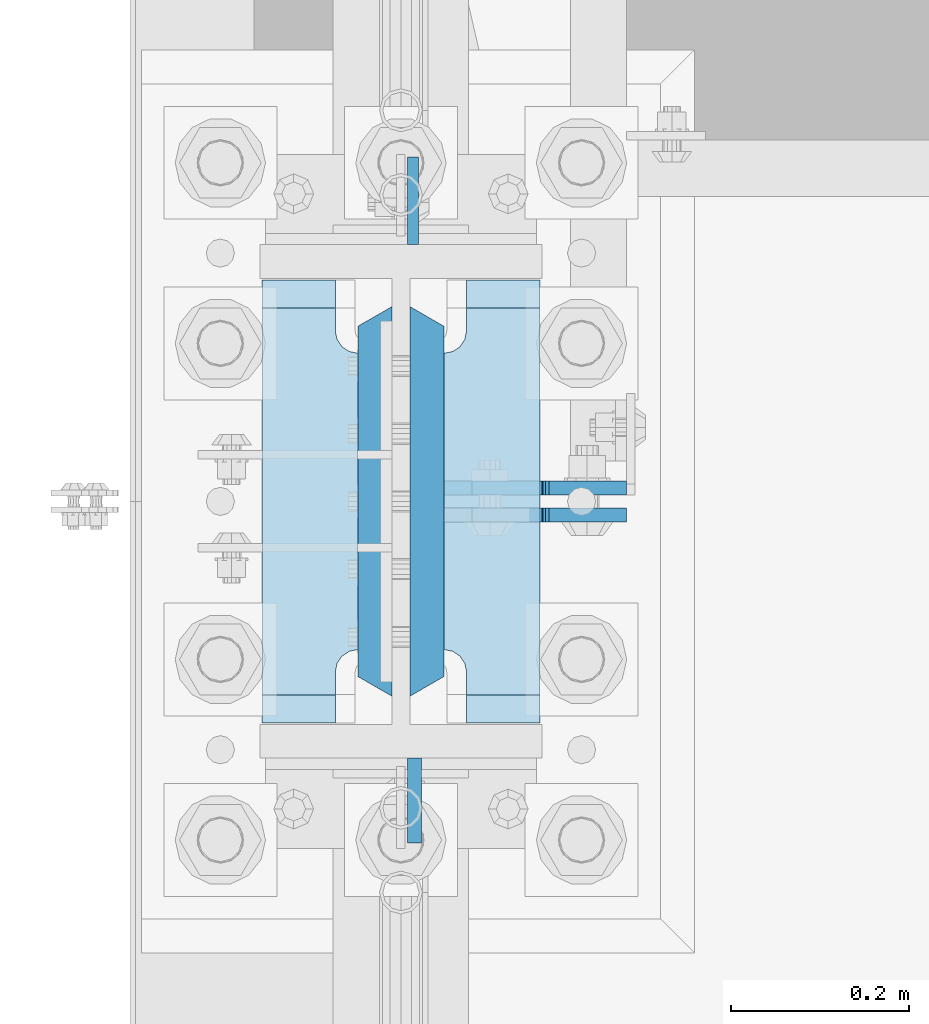
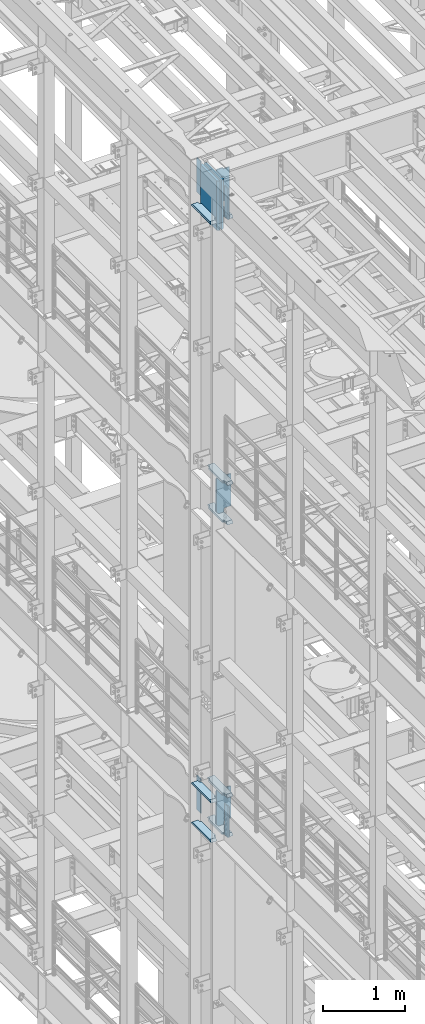
# One storey, part 1550 of 1876: 17 plates, 2 elements without a shape of their own.
"""IFC2X3 building model written with IfcOpenShell, lengths in millimetres."""

from ifc_helpers import new_model, si_unit, frame, origin_with_axes, place, context, subcontext, project, spatial, faceted_brep, material, type_object, element, aggregate, save


model = new_model("IFC2X3")

# Units and contexts
model_context = context("Model", 3, precision=1e-05, world=origin_with_axes())
body_context = subcontext(model_context, "Body", "Model", "MODEL_VIEW")
ifc_project = project(units=[si_unit("LENGTHUNIT", "METRE", prefix="MILLI"), si_unit("AREAUNIT", "SQUARE_METRE"), si_unit("VOLUMEUNIT", "CUBIC_METRE"), si_unit("MASSUNIT", "GRAM", prefix="KILO"), si_unit("TIMEUNIT", "SECOND"), si_unit("PLANEANGLEUNIT", "RADIAN"), si_unit("SOLIDANGLEUNIT", "STERADIAN"), si_unit("THERMODYNAMICTEMPERATUREUNIT", "DEGREE_CELSIUS"), si_unit("LUMINOUSINTENSITYUNIT", "LUMEN")], contexts=[model_context])

# Site, building, storey
site_placement = place(None, origin_with_axes())
site = spatial("IfcSite", under=ifc_project, at=site_placement, CompositionType="ELEMENT")
building_placement = place(site_placement, origin_with_axes())
building = spatial("IfcBuilding", under=site, at=building_placement, Name="Undefined", CompositionType="ELEMENT")
storey_placement = place(building_placement, origin_with_axes())
storey = spatial("IfcBuildingStorey", under=building, at=storey_placement, Name="Undefined", CompositionType="ELEMENT", Elevation=0.0)

# Assembly, plate
assembly_1_placement = place(storey_placement, origin_with_axes())
assembly_1 = element("IfcElementAssembly", 1, at=assembly_1_placement, inside=storey, Name="COLUMN", AssemblyPlace="NOTDEFINED", PredefinedType="RIGID_FRAME")
ifc_material_1 = material(Name="STEEL/A572-50")
plate_type_1 = type_object("IfcPlateType", PredefinedType="NOTDEFINED")
plate_1_placement = place(assembly_1_placement, frame((13.493000125885, 1812.925, 22501.225), z_axis=(0.0, 1.0, 0.0), x_axis=(0.0, 0.0, -1.0)))
plate_1 = element("IfcPlate", 2, at=plate_1_placement, type_object=plate_type_1, material=ifc_material_1, Name="PLATE", context=body_context, shape_type="Brep", body=[
    faceted_brep([(0.0, -6.35000000000036, 0.0), (0.0, -6.34999999999991, 98.4250030517578), (0.0, 6.34999999999991, 98.4250030517578), (0.0, 6.35000000000036, 0.0), (514.349975585938, -6.35000000000036, 98.4250030517578), (514.349975585938, 6.35000000000036, 98.4250030517578), (514.349975585938, -6.35000000000036, 0.0), (514.349975585938, 6.35000000000036, 0.0)], [[[0, 1, 2, 3]], [[1, 4, 5, 2]], [[4, 6, 7, 5]], [[6, 0, 3, 7]], [[5, 7, 3, 2]], [[6, 4, 1, 0]]]),
])

assembly_2_placement = place(storey_placement, origin_with_axes())
assembly_2 = element("IfcElementAssembly", 3, at=assembly_2_placement, inside=storey, Name="COLUMN", AssemblyPlace="NOTDEFINED", PredefinedType="RIGID_FRAME")
plate_2_placement = place(assembly_2_placement, frame((13.493000125885, 1812.925, 13255.625), z_axis=(0.0, 1.0, 0.0), x_axis=(0.0, 0.0, -1.0)))
plate_2 = element("IfcPlate", 4, at=plate_2_placement, type_object=plate_type_1, material=ifc_material_1, Name="PLATE", context=body_context, shape_type="Brep", body=[
    faceted_brep([(0.0, -6.35000000000036, 0.0), (0.0, -6.34999999999991, 98.4250030517578), (0.0, 6.34999999999991, 98.4250030517578), (0.0, 6.35000000000036, 0.0), (514.349975585938, -6.35000000000036, 98.4250030517578), (514.349975585938, 6.35000000000036, 98.4250030517578), (514.349975585938, -6.35000000000036, 0.0), (514.349975585938, 6.35000000000036, 0.0)], [[[0, 1, 2, 3]], [[1, 4, 5, 2]], [[4, 6, 7, 5]], [[6, 0, 3, 7]], [[5, 7, 3, 2]], [[6, 4, 1, 0]]]),
])

# Plate
ifc_material_2 = material(Name="STEEL/A572-GR.50")
plate_type_2 = type_object("IfcPlateType", PredefinedType="NOTDEFINED")
plate_3_placement = place(assembly_1_placement, frame((29.3687499999999, 1743.075, 22523.45), z_axis=(0.0, -1.0, 0.0), x_axis=(0.0, 0.0, -1.0)))
plate_3 = element("IfcPlate", 5, at=plate_3_placement, type_object=plate_type_2, material=ifc_material_2, Name="PLATE", context=body_context, shape_type="Brep", body=[
    faceted_brep([(0.0, 19.0500000000002, 416.152954742277), (0.0, -19.0500000000002, 438.149993896484), (742.950012207031, -19.0500000000002, 438.149993896484), (742.950012207031, 19.0500000000002, 416.152954742277), (742.950012207031, 19.0500000000002, 21.9970452577325), (0.0, 19.0500000000002, 21.9970452577367), (0.0, -19.0500000000002, 0.0), (742.950012207031, -19.0500000000002, 0.0)], [[[0, 1, 2, 3]], [[0, 3, 4, 5]], [[1, 0, 5, 6]], [[2, 1, 6, 7]], [[3, 2, 7, 4]], [[6, 5, 4, 7]]]),
])

plate_4_placement = place(assembly_1_placement, frame((-29.3687499999999, 1743.075, 22523.45), z_axis=(0.0, -1.0, 0.0), x_axis=(0.0, 0.0, -1.0)))
plate_4 = element("IfcPlate", 6, at=plate_4_placement, type_object=plate_type_2, material=ifc_material_2, Name="PLATE", context=body_context, shape_type="Brep", body=[
    faceted_brep([(0.0, -19.0500000000002, 416.152954749452), (742.950012207031, -19.0500000000002, 416.152954749372), (742.950012207031, 19.0500000000002, 438.149993896484), (0.0, 19.0500000000002, 438.149993896484), (742.950012207031, -19.0500000000002, 21.9970452506512), (742.950012207031, 19.0500000000002, 0.0), (-9.09494701772928e-13, 19.05, -1.81898940354586e-12), (0.0, -19.0500000000002, 21.9970452506512)], [[[0, 1, 2, 3]], [[2, 1, 4, 5]], [[3, 2, 5, 6]], [[0, 3, 6, 7]], [[1, 0, 7, 4]], [[6, 5, 4, 7]]]),
])

plate_type_3 = type_object("IfcPlateType", PredefinedType="NOTDEFINED")
plate_5_placement = place(assembly_1_placement, frame((15.080500125885, 1235.075, 22491.7), z_axis=(0.0, -1.0, 0.0), x_axis=(0.0, 0.0, -1.0)))
plate_5 = element("IfcPlate", 7, at=plate_5_placement, type_object=plate_type_3, material=ifc_material_1, Name="PLATE", context=body_context, shape_type="Brep", body=[
    faceted_brep([(0.0, -7.9375, 0.0), (0.0, -7.9375, 95.25), (0.0, 7.9375, 95.25), (0.0, 7.9375, 0.0), (457.200012207031, -7.9375, 95.25), (457.200012207031, 7.9375, 95.25), (457.200012207031, -7.9375, 0.0), (457.200012207031, 7.9375, 0.0)], [[[0, 1, 2, 3]], [[1, 4, 5, 2]], [[4, 6, 7, 5]], [[6, 0, 3, 7]], [[5, 7, 3, 2]], [[6, 4, 1, 0]]]),
])

ifc_material_3 = material(Name="STEEL/A36")
plate_6_placement = place(assembly_2_placement, frame((15.080500125885, 1235.075, 13246.1), z_axis=(0.0, -1.0, 0.0), x_axis=(0.0, 0.0, -1.0)))
plate_6 = element("IfcPlate", 8, at=plate_6_placement, type_object=plate_type_3, material=ifc_material_3, Name="PLATE", context=body_context, shape_type="Brep", body=[
    faceted_brep([(0.0, -7.9375, 0.0), (0.0, -7.9375, 95.25), (0.0, 7.9375, 95.25), (0.0, 7.9375, 0.0), (457.200012207031, -7.9375, 95.25), (457.200012207031, 7.9375, 95.25), (457.200012207031, -7.9375, 0.0), (457.200012207031, 7.9375, 0.0)], [[[0, 1, 2, 3]], [[1, 4, 5, 2]], [[4, 6, 7, 5]], [[6, 0, 3, 7]], [[5, 7, 3, 2]], [[6, 4, 1, 0]]]),
])

plate_type_4 = type_object("IfcPlateType", PredefinedType="NOTDEFINED")
plate_7_placement = place(assembly_1_placement, frame((156.36875, 1274.7625, 17376.775012207), z_axis=(0.0, 1.0, 0.0), x_axis=(-1.0, 0.0, 0.0)))
plate_7 = element("IfcPlate", 9, at=plate_7_placement, type_object=plate_type_4, material=ifc_material_1, Name="PLATE", context=body_context, shape_type="Brep", body=[
    faceted_brep([(82.5499973297119, -15.875, 498.475006103516), (82.5499973297119, 15.875, 467.025007631571), (0.0, 15.875, 467.025007631571), (0.0, -15.875, 498.475006103516), (82.5499973297119, 15.875, 31.449998471945), (82.5499973297119, -15.875, 0.0), (0.0, -15.875, 0.0), (0.0, 15.875, 31.449998471945), (82.5499973297119, 15.875, 57.1500034332275), (82.5499973297119, -15.875, 57.1500034332275), (84.4834571748879, -15.875, 66.8701624693188), (84.4834571748879, 15.875, 66.8701624693188), (89.9894849758439, -15.875, 75.1105154056261), (89.9894849758439, 15.875, 75.1105154056261), (98.2298379121512, -15.875, 80.616543206582), (98.2298379121512, 15.875, 80.616543206582), (107.949996948242, -15.875, 82.5500030517578), (107.949996948242, 15.875, 82.5500030517578), (107.949996948242, -15.875, 415.925003051758), (107.949996948242, 15.875, 415.925003051758), (98.2298379121512, -15.875, 417.858462896934), (98.2298379121512, 15.875, 417.858462896934), (89.9894849758439, -15.875, 423.36449069789), (89.9894849758439, 15.875, 423.36449069789), (84.483457174887, -15.875, 431.604843634197), (84.483457174887, 15.875, 431.604843634197), (82.5499973297119, -15.875, 441.325002670288), (82.5499973297119, 15.875, 441.325002670288)], [[[0, 1, 2, 3]], [[4, 5, 6, 7]], [[8, 9, 5, 4]], [[10, 9, 8, 11]], [[12, 10, 11, 13]], [[14, 12, 13, 15]], [[16, 14, 15, 17]], [[18, 16, 17, 19]], [[20, 18, 19, 21]], [[22, 20, 21, 23]], [[24, 22, 23, 25]], [[26, 24, 25, 27]], [[6, 5, 9, 10, 12, 14, 16, 18, 20, 22, 24, 26, 0, 3]], [[7, 6, 3, 2]], [[27, 25, 23, 21, 19, 17, 15, 13, 11, 8, 4, 7, 2, 1]], [[26, 27, 1, 0]]]),
])

plate_8_placement = place(assembly_1_placement, frame((156.36875, 1274.7625, 17967.325), z_axis=(0.0, 1.0, 0.0), x_axis=(-1.0, 0.0, 0.0)))
plate_8 = element("IfcPlate", 10, at=plate_8_placement, type_object=plate_type_4, material=ifc_material_1, Name="PLATE", context=body_context, shape_type="Brep", body=[
    faceted_brep([(82.5499973297119, -15.875, 498.475006103516), (82.5499973297119, 15.875, 467.025007631571), (0.0, 15.875, 467.025007631571), (0.0, -15.875, 498.475006103516), (82.5499973297119, 15.875, 31.449998471945), (82.5499973297119, -15.875, 0.0), (0.0, -15.875, 0.0), (0.0, 15.875, 31.449998471945), (82.5499973297119, 15.875, 57.1500034332275), (82.5499973297119, -15.875, 57.1500034332275), (84.4834571748879, -15.875, 66.8701624693188), (84.4834571748879, 15.875, 66.8701624693188), (89.9894849758439, -15.875, 75.1105154056261), (89.9894849758439, 15.875, 75.1105154056261), (98.2298379121512, -15.875, 80.616543206582), (98.2298379121512, 15.875, 80.616543206582), (107.949996948242, -15.875, 82.5500030517578), (107.949996948242, 15.875, 82.5500030517578), (107.949996948242, -15.875, 415.925003051758), (107.949996948242, 15.875, 415.925003051758), (98.2298379121512, -15.875, 417.858462896934), (98.2298379121512, 15.875, 417.858462896934), (89.9894849758439, -15.875, 423.36449069789), (89.9894849758439, 15.875, 423.36449069789), (84.483457174887, -15.875, 431.604843634197), (84.483457174887, 15.875, 431.604843634197), (82.5499973297119, -15.875, 441.325002670288), (82.5499973297119, 15.875, 441.325002670288)], [[[0, 1, 2, 3]], [[4, 5, 6, 7]], [[8, 9, 5, 4]], [[10, 9, 8, 11]], [[12, 10, 11, 13]], [[14, 12, 13, 15]], [[16, 14, 15, 17]], [[18, 16, 17, 19]], [[20, 18, 19, 21]], [[22, 20, 21, 23]], [[24, 22, 23, 25]], [[26, 24, 25, 27]], [[6, 5, 9, 10, 12, 14, 16, 18, 20, 22, 24, 26, 0, 3]], [[7, 6, 3, 2]], [[27, 25, 23, 21, 19, 17, 15, 13, 11, 8, 4, 7, 2, 1]], [[26, 27, 1, 0]]]),
])

plate_9_placement = place(assembly_1_placement, frame((-48.41875, 1274.7625, 21948.775012207), z_axis=(0.0, 1.0, 0.0), x_axis=(-1.0, 0.0, 0.0)))
plate_9 = element("IfcPlate", 11, at=plate_9_placement, type_object=plate_type_4, material=ifc_material_1, Name="PLATE", context=body_context, shape_type="Brep", body=[
    faceted_brep([(107.949996948242, -15.875, 498.475006103516), (107.949996948242, 15.875, 467.025007631571), (25.3999996185303, 15.875, 467.025007631571), (25.3999996185303, -15.875, 498.475006103516), (23.4665397733561, -15.875, 431.604843634198), (25.3999996185303, -15.875, 441.325002670288), (25.3999996185303, 15.875, 441.325002670288), (23.4665397733561, 15.875, 431.604843634198), (17.9605119724001, -15.875, 423.36449069789), (17.9605119724001, 15.875, 423.36449069789), (9.72015903609281, -15.875, 417.858462896934), (9.72015903609281, 15.875, 417.858462896934), (0.0, -15.875, 415.925003051758), (0.0, 15.875, 415.925003051758), (0.0, -15.875, 82.5500030517578), (0.0, 15.875, 82.5500030517578), (9.72015903609099, -15.875, 80.616543206582), (9.72015903609099, 15.875, 80.616543206582), (17.9605119723983, -15.875, 75.1105154056258), (17.9605119723983, 15.875, 75.1105154056258), (23.4665397733552, -15.875, 66.8701624693183), (23.4665397733552, 15.875, 66.8701624693183), (25.3999996185303, -15.875, 57.1500034332275), (25.3999996185303, 15.875, 57.1500034332275), (25.3999996185303, 15.875, 31.449998471945), (25.3999996185303, -15.875, 0.0), (107.949996948242, 15.875, 31.449998471945), (107.949996948242, -15.875, 0.0)], [[[0, 1, 2, 3]], [[4, 5, 6, 7]], [[8, 4, 7, 9]], [[10, 8, 9, 11]], [[12, 10, 11, 13]], [[14, 12, 13, 15]], [[16, 14, 15, 17]], [[18, 16, 17, 19]], [[20, 18, 19, 21]], [[22, 20, 21, 23]], [[22, 23, 24, 25]], [[26, 27, 25, 24]], [[5, 4, 8, 10, 12, 14, 16, 18, 20, 22, 25, 27, 0, 3]], [[6, 5, 3, 2]], [[26, 24, 23, 21, 19, 17, 15, 13, 11, 9, 7, 6, 2, 1]], [[27, 26, 1, 0]]]),
])

plate_10_placement = place(assembly_1_placement, frame((156.36875, 1274.7625, 21948.775012207), z_axis=(0.0, 1.0, 0.0), x_axis=(-1.0, 0.0, 0.0)))
plate_10 = element("IfcPlate", 12, at=plate_10_placement, type_object=plate_type_4, material=ifc_material_1, Name="PLATE", context=body_context, shape_type="Brep", body=[
    faceted_brep([(82.5499973297119, -15.875, 498.475006103516), (82.5499973297119, 15.875, 467.025007631571), (0.0, 15.875, 467.025007631571), (0.0, -15.875, 498.475006103516), (82.5499973297119, 15.875, 31.449998471945), (82.5499973297119, -15.875, 0.0), (0.0, -15.875, 0.0), (0.0, 15.875, 31.449998471945), (82.5499973297119, 15.875, 57.1500034332275), (82.5499973297119, -15.875, 57.1500034332275), (84.4834571748879, -15.875, 66.8701624693188), (84.4834571748879, 15.875, 66.8701624693188), (89.9894849758439, -15.875, 75.1105154056261), (89.9894849758439, 15.875, 75.1105154056261), (98.2298379121512, -15.875, 80.616543206582), (98.2298379121512, 15.875, 80.616543206582), (107.949996948242, -15.875, 82.5500030517578), (107.949996948242, 15.875, 82.5500030517578), (107.949996948242, -15.875, 415.925003051758), (107.949996948242, 15.875, 415.925003051758), (98.2298379121512, -15.875, 417.858462896934), (98.2298379121512, 15.875, 417.858462896934), (89.9894849758439, -15.875, 423.36449069789), (89.9894849758439, 15.875, 423.36449069789), (84.483457174887, -15.875, 431.604843634197), (84.483457174887, 15.875, 431.604843634197), (82.5499973297119, -15.875, 441.325002670288), (82.5499973297119, 15.875, 441.325002670288)], [[[0, 1, 2, 3]], [[4, 5, 6, 7]], [[8, 9, 5, 4]], [[10, 9, 8, 11]], [[12, 10, 11, 13]], [[14, 12, 13, 15]], [[16, 14, 15, 17]], [[18, 16, 17, 19]], [[20, 18, 19, 21]], [[22, 20, 21, 23]], [[24, 22, 23, 25]], [[26, 24, 25, 27]], [[6, 5, 9, 10, 12, 14, 16, 18, 20, 22, 24, 26, 0, 3]], [[7, 6, 3, 2]], [[27, 25, 23, 21, 19, 17, 15, 13, 11, 8, 4, 7, 2, 1]], [[26, 27, 1, 0]]]),
])

plate_11_placement = place(assembly_2_placement, frame((-48.41875, 1274.7625, 12703.175012207), z_axis=(0.0, 1.0, 0.0), x_axis=(-1.0, 0.0, 0.0)))
plate_11 = element("IfcPlate", 13, at=plate_11_placement, type_object=plate_type_4, material=ifc_material_1, Name="PLATE", context=body_context, shape_type="Brep", body=[
    faceted_brep([(107.949996948242, -15.875, 498.475006103516), (107.949996948242, 15.875, 467.025007631571), (25.3999996185303, 15.875, 467.025007631571), (25.3999996185303, -15.875, 498.475006103516), (23.4665397733561, -15.875, 431.604843634198), (25.3999996185303, -15.875, 441.325002670288), (25.3999996185303, 15.875, 441.325002670288), (23.4665397733561, 15.875, 431.604843634198), (17.9605119724001, -15.875, 423.36449069789), (17.9605119724001, 15.875, 423.36449069789), (9.72015903609281, -15.875, 417.858462896934), (9.72015903609281, 15.875, 417.858462896934), (0.0, -15.875, 415.925003051758), (0.0, 15.875, 415.925003051758), (0.0, -15.875, 82.5500030517578), (0.0, 15.875, 82.5500030517578), (9.72015903609099, -15.875, 80.616543206582), (9.72015903609099, 15.875, 80.616543206582), (17.9605119723983, -15.875, 75.1105154056258), (17.9605119723983, 15.875, 75.1105154056258), (23.4665397733552, -15.875, 66.8701624693183), (23.4665397733552, 15.875, 66.8701624693183), (25.3999996185303, -15.875, 57.1500034332275), (25.3999996185303, 15.875, 57.1500034332275), (25.3999996185303, 15.875, 31.449998471945), (25.3999996185303, -15.875, 0.0), (107.949996948242, 15.875, 31.449998471945), (107.949996948242, -15.875, 0.0)], [[[0, 1, 2, 3]], [[4, 5, 6, 7]], [[8, 4, 7, 9]], [[10, 8, 9, 11]], [[12, 10, 11, 13]], [[14, 12, 13, 15]], [[16, 14, 15, 17]], [[18, 16, 17, 19]], [[20, 18, 19, 21]], [[22, 20, 21, 23]], [[22, 23, 24, 25]], [[26, 27, 25, 24]], [[5, 4, 8, 10, 12, 14, 16, 18, 20, 22, 25, 27, 0, 3]], [[6, 5, 3, 2]], [[26, 24, 23, 21, 19, 17, 15, 13, 11, 9, 7, 6, 2, 1]], [[27, 26, 1, 0]]]),
])

plate_12_placement = place(assembly_2_placement, frame((-48.41875, 1274.7625, 13293.725), z_axis=(0.0, 1.0, 0.0), x_axis=(-1.0, 0.0, 0.0)))
plate_12 = element("IfcPlate", 14, at=plate_12_placement, type_object=plate_type_4, material=ifc_material_1, Name="PLATE", context=body_context, shape_type="Brep", body=[
    faceted_brep([(107.949996948242, -15.875, 498.475006103516), (107.949996948242, 15.875, 467.025007631571), (25.3999996185303, 15.875, 467.025007631571), (25.3999996185303, -15.875, 498.475006103516), (23.4665397733561, -15.875, 431.604843634198), (25.3999996185303, -15.875, 441.325002670288), (25.3999996185303, 15.875, 441.325002670288), (23.4665397733561, 15.875, 431.604843634198), (17.9605119724001, -15.875, 423.36449069789), (17.9605119724001, 15.875, 423.36449069789), (9.72015903609281, -15.875, 417.858462896934), (9.72015903609281, 15.875, 417.858462896934), (0.0, -15.875, 415.925003051758), (0.0, 15.875, 415.925003051758), (0.0, -15.875, 82.5500030517578), (0.0, 15.875, 82.5500030517578), (9.72015903609099, -15.875, 80.616543206582), (9.72015903609099, 15.875, 80.616543206582), (17.9605119723983, -15.875, 75.1105154056258), (17.9605119723983, 15.875, 75.1105154056258), (23.4665397733552, -15.875, 66.8701624693183), (23.4665397733552, 15.875, 66.8701624693183), (25.3999996185303, -15.875, 57.1500034332275), (25.3999996185303, 15.875, 57.1500034332275), (25.3999996185303, 15.875, 31.449998471945), (25.3999996185303, -15.875, 0.0), (107.949996948242, 15.875, 31.449998471945), (107.949996948242, -15.875, 0.0)], [[[0, 1, 2, 3]], [[4, 5, 6, 7]], [[8, 4, 7, 9]], [[10, 8, 9, 11]], [[12, 10, 11, 13]], [[14, 12, 13, 15]], [[16, 14, 15, 17]], [[18, 16, 17, 19]], [[20, 18, 19, 21]], [[22, 20, 21, 23]], [[22, 23, 24, 25]], [[26, 27, 25, 24]], [[5, 4, 8, 10, 12, 14, 16, 18, 20, 22, 25, 27, 0, 3]], [[6, 5, 3, 2]], [[26, 24, 23, 21, 19, 17, 15, 13, 11, 9, 7, 6, 2, 1]], [[27, 26, 1, 0]]]),
])

plate_13_placement = place(assembly_2_placement, frame((156.36875, 1274.7625, 12703.175012207), z_axis=(0.0, 1.0, 0.0), x_axis=(-1.0, 0.0, 0.0)))
plate_13 = element("IfcPlate", 15, at=plate_13_placement, type_object=plate_type_4, material=ifc_material_1, Name="PLATE", context=body_context, shape_type="Brep", body=[
    faceted_brep([(82.5499973297119, -15.875, 498.475006103516), (82.5499973297119, 15.875, 467.025007631571), (0.0, 15.875, 467.025007631571), (0.0, -15.875, 498.475006103516), (82.5499973297119, 15.875, 31.449998471945), (82.5499973297119, -15.875, 0.0), (0.0, -15.875, 0.0), (0.0, 15.875, 31.449998471945), (82.5499973297119, 15.875, 57.1500034332275), (82.5499973297119, -15.875, 57.1500034332275), (84.4834571748879, -15.875, 66.8701624693188), (84.4834571748879, 15.875, 66.8701624693188), (89.9894849758439, -15.875, 75.1105154056261), (89.9894849758439, 15.875, 75.1105154056261), (98.2298379121512, -15.875, 80.616543206582), (98.2298379121512, 15.875, 80.616543206582), (107.949996948242, -15.875, 82.5500030517578), (107.949996948242, 15.875, 82.5500030517578), (107.949996948242, -15.875, 415.925003051758), (107.949996948242, 15.875, 415.925003051758), (98.2298379121512, -15.875, 417.858462896934), (98.2298379121512, 15.875, 417.858462896934), (89.9894849758439, -15.875, 423.36449069789), (89.9894849758439, 15.875, 423.36449069789), (84.483457174887, -15.875, 431.604843634197), (84.483457174887, 15.875, 431.604843634197), (82.5499973297119, -15.875, 441.325002670288), (82.5499973297119, 15.875, 441.325002670288)], [[[0, 1, 2, 3]], [[4, 5, 6, 7]], [[8, 9, 5, 4]], [[10, 9, 8, 11]], [[12, 10, 11, 13]], [[14, 12, 13, 15]], [[16, 14, 15, 17]], [[18, 16, 17, 19]], [[20, 18, 19, 21]], [[22, 20, 21, 23]], [[24, 22, 23, 25]], [[26, 24, 25, 27]], [[6, 5, 9, 10, 12, 14, 16, 18, 20, 22, 24, 26, 0, 3]], [[7, 6, 3, 2]], [[27, 25, 23, 21, 19, 17, 15, 13, 11, 8, 4, 7, 2, 1]], [[26, 27, 1, 0]]]),
])

plate_14_placement = place(assembly_2_placement, frame((156.36875, 1274.7625, 13293.725), z_axis=(0.0, 1.0, 0.0), x_axis=(-1.0, 0.0, 0.0)))
plate_14 = element("IfcPlate", 16, at=plate_14_placement, type_object=plate_type_4, material=ifc_material_1, Name="PLATE", context=body_context, shape_type="Brep", body=[
    faceted_brep([(82.5499973297119, -15.875, 498.475006103516), (82.5499973297119, 15.875, 467.025007631571), (0.0, 15.875, 467.025007631571), (0.0, -15.875, 498.475006103516), (82.5499973297119, 15.875, 31.449998471945), (82.5499973297119, -15.875, 0.0), (0.0, -15.875, 0.0), (0.0, 15.875, 31.449998471945), (82.5499973297119, 15.875, 57.1500034332275), (82.5499973297119, -15.875, 57.1500034332275), (84.4834571748879, -15.875, 66.8701624693188), (84.4834571748879, 15.875, 66.8701624693188), (89.9894849758439, -15.875, 75.1105154056261), (89.9894849758439, 15.875, 75.1105154056261), (98.2298379121512, -15.875, 80.616543206582), (98.2298379121512, 15.875, 80.616543206582), (107.949996948242, -15.875, 82.5500030517578), (107.949996948242, 15.875, 82.5500030517578), (107.949996948242, -15.875, 415.925003051758), (107.949996948242, 15.875, 415.925003051758), (98.2298379121512, -15.875, 417.858462896934), (98.2298379121512, 15.875, 417.858462896934), (89.9894849758439, -15.875, 423.36449069789), (89.9894849758439, 15.875, 423.36449069789), (84.483457174887, -15.875, 431.604843634197), (84.483457174887, 15.875, 431.604843634197), (82.5499973297119, -15.875, 441.325002670288), (82.5499973297119, 15.875, 441.325002670288)], [[[0, 1, 2, 3]], [[4, 5, 6, 7]], [[8, 9, 5, 4]], [[10, 9, 8, 11]], [[12, 10, 11, 13]], [[14, 12, 13, 15]], [[16, 14, 15, 17]], [[18, 16, 17, 19]], [[20, 18, 19, 21]], [[22, 20, 21, 23]], [[24, 22, 23, 25]], [[26, 24, 25, 27]], [[6, 5, 9, 10, 12, 14, 16, 18, 20, 22, 24, 26, 0, 3]], [[7, 6, 3, 2]], [[27, 25, 23, 21, 19, 17, 15, 13, 11, 8, 4, 7, 2, 1]], [[26, 27, 1, 0]]]),
])

plate_type_5 = type_object("IfcPlateType", PredefinedType="NOTDEFINED")
plate_15_placement = place(assembly_1_placement, frame((48.4187500000006, 1508.91875, 17951.45), z_axis=(1.0, 0.0, 0.0), x_axis=(0.0, 0.0, -1.0)))
plate_15 = element("IfcPlate", 17, at=plate_15_placement, type_object=plate_type_5, material=ifc_material_3, Name="PLATE", context=body_context, shape_type="Brep", body=[
    faceted_brep([(501.650012207032, -7.9375, 205.581252728631), (501.650012207032, -7.9375, 123.031246757509), (501.650012207032, 7.9375, 123.031246757509), (501.650012207032, 7.9375, 205.581253051758), (502.61674212962, -7.9375, 118.171167239463), (502.61674212962, 7.9375, 118.171167239463), (505.369756030097, -7.9375, 114.050990771309), (505.369756030097, 7.9375, 114.050990771309), (509.489932498251, -7.9375, 111.297976870831), (509.489932498251, 7.9375, 111.297976870831), (514.350012016297, -7.9375, 110.331246948243), (514.350012016297, 7.9375, 110.331246948243), (558.799987792969, -7.9375, 110.331246948243), (558.799987792969, 7.9375, 110.331246948243), (19.0499992370605, -7.9375, 205.58125), (19.0499992370605, 7.9375, 205.581253051758), (19.0499992370605, 7.9375, 123.031249809265), (19.0499992370605, -7.9375, 123.031249809265), (18.083269314473, 7.9375, 118.17117029122), (18.083269314473, -7.9375, 118.17117029122), (15.3302554139955, 7.9375, 114.050993823066), (15.3302554139955, -7.9375, 114.050993823066), (11.2100789458418, 7.9375, 111.297979922588), (11.2100789458418, -7.9375, 111.297979922588), (6.34999942779541, 7.9375, 110.33125), (6.34999942779541, -7.9375, 110.33125), (0.0, 7.9375, 110.33125), (0.0, -7.9375, 110.33125), (0.0, 7.93749999999999, 31.75), (0.0, -7.93749999999998, 31.75), (31.75, -7.93749999999998, 0.0), (31.75, 7.93749999999999, 0.0), (527.049987792969, -7.93749999999998, 0.0), (527.049987792969, 7.93749999999999, 0.0), (558.799987792969, -7.93749999999998, 31.75), (558.799987792969, 7.93749999999999, 31.75)], [[[0, 1, 2, 3]], [[4, 5, 2, 1]], [[6, 7, 5, 4]], [[8, 9, 7, 6]], [[10, 11, 9, 8]], [[12, 13, 11, 10]], [[14, 15, 16, 17]], [[17, 16, 18, 19]], [[19, 18, 20, 21]], [[21, 20, 22, 23]], [[23, 22, 24, 25]], [[25, 24, 26, 27]], [[28, 29, 27, 26]], [[30, 29, 28, 31]], [[32, 30, 31, 33]], [[34, 32, 33, 35]], [[8, 6, 4, 1, 0, 14, 17, 19, 21, 23, 25, 27, 29, 30, 32, 34, 12, 10]], [[15, 14, 0, 3]], [[35, 33, 31, 28, 26, 24, 22, 20, 18, 16, 15, 3, 2, 5, 7, 9, 11, 13]], [[34, 35, 13, 12]]]),
])

plate_16_placement = place(assembly_1_placement, frame((48.4187500000006, 1539.08125, 22523.45), z_axis=(1.0, 0.0, 0.0), x_axis=(0.0, 0.0, -1.0)))
plate_16 = element("IfcPlate", 18, at=plate_16_placement, type_object=plate_type_5, material=ifc_material_3, Name="PLATE", context=body_context, shape_type="Brep", body=[
    faceted_brep([(501.650012207032, -7.9375, 205.581252728631), (501.650012207032, -7.9375, 123.031246757509), (501.650012207032, 7.9375, 123.031246757509), (501.650012207032, 7.9375, 205.581253051758), (502.61674212962, -7.9375, 118.171167239463), (502.61674212962, 7.9375, 118.171167239463), (505.369756030097, -7.9375, 114.050990771309), (505.369756030097, 7.9375, 114.050990771309), (509.489932498251, -7.9375, 111.297976870831), (509.489932498251, 7.9375, 111.297976870831), (514.350012016297, -7.9375, 110.331246948243), (514.350012016297, 7.9375, 110.331246948243), (558.799987792969, -7.9375, 110.331246948243), (558.799987792969, 7.9375, 110.331246948243), (19.0499992370605, -7.9375, 205.58125), (19.0499992370605, 7.9375, 205.581253051758), (19.0499992370605, 7.9375, 123.031495651009), (19.0499992370605, -7.9375, 123.031495651009), (18.083269314473, 7.9375, 118.171416132964), (18.083269314473, -7.9375, 118.171416132964), (15.3302554139955, 7.9375, 114.05123966481), (15.3302554139955, -7.9375, 114.05123966481), (11.2100789458418, 7.9375, 111.298225764332), (11.2100789458418, -7.9375, 111.298225764332), (6.34999942779541, 7.9375, 110.331495841744), (6.34999942779541, -7.9375, 110.331495841744), (0.0, 7.9375, 110.331495841744), (0.0, -7.9375, 110.331495841744), (0.0, 7.93749999999999, 31.75), (0.0, -7.93749999999998, 31.75), (31.75, -7.93749999999998, 0.0), (31.75, 7.93749999999999, 0.0), (527.049987792969, -7.93749999999998, 0.0), (527.049987792969, 7.93749999999999, 0.0), (558.799987792969, -7.93749999999998, 31.75), (558.799987792969, 7.93749999999999, 31.75)], [[[0, 1, 2, 3]], [[4, 5, 2, 1]], [[6, 7, 5, 4]], [[8, 9, 7, 6]], [[10, 11, 9, 8]], [[12, 13, 11, 10]], [[14, 15, 16, 17]], [[17, 16, 18, 19]], [[19, 18, 20, 21]], [[21, 20, 22, 23]], [[23, 22, 24, 25]], [[25, 24, 26, 27]], [[28, 29, 27, 26]], [[30, 29, 28, 31]], [[32, 30, 31, 33]], [[34, 32, 33, 35]], [[8, 6, 4, 1, 0, 14, 17, 19, 21, 23, 25, 27, 29, 30, 32, 34, 12, 10]], [[15, 14, 0, 3]], [[35, 33, 31, 28, 26, 24, 22, 20, 18, 16, 15, 3, 2, 5, 7, 9, 11, 13]], [[34, 35, 13, 12]]]),
])

aggregate(assembly_1, [plate_7, plate_8, plate_15, plate_9, plate_10, plate_16, plate_3, plate_4, plate_1, plate_5])

plate_17_placement = place(assembly_2_placement, frame((48.4187500000002, 1508.91875, 13277.85), z_axis=(1.0, 0.0, 0.0), x_axis=(0.0, 0.0, -1.0)))
plate_17 = element("IfcPlate", 19, at=plate_17_placement, type_object=plate_type_5, material=ifc_material_3, Name="PLATE", context=body_context, shape_type="Brep", body=[
    faceted_brep([(501.650012207032, -7.9375, 205.581252728631), (501.650012207032, -7.9375, 123.031246757509), (501.650012207032, 7.9375, 123.031246757509), (501.650012207032, 7.9375, 205.581253051758), (502.61674212962, -7.9375, 118.171167239463), (502.61674212962, 7.9375, 118.171167239463), (505.369756030097, -7.9375, 114.050990771309), (505.369756030097, 7.9375, 114.050990771309), (509.489932498251, -7.9375, 111.297976870831), (509.489932498251, 7.9375, 111.297976870831), (514.350012016297, -7.9375, 110.331246948243), (514.350012016297, 7.9375, 110.331246948243), (558.799987792969, -7.9375, 110.331246948243), (558.799987792969, 7.9375, 110.331246948243), (19.0499992370605, -7.9375, 205.58125), (19.0499992370605, 7.9375, 205.581253051758), (19.0499992370605, 7.9375, 123.031249809265), (19.0499992370605, -7.9375, 123.031249809265), (18.083269314473, 7.9375, 118.17117029122), (18.083269314473, -7.9375, 118.17117029122), (15.3302554139955, 7.9375, 114.050993823066), (15.3302554139955, -7.9375, 114.050993823066), (11.2100789458418, 7.9375, 111.297979922588), (11.2100789458418, -7.9375, 111.297979922588), (6.34999942779541, 7.9375, 110.33125), (6.34999942779541, -7.9375, 110.33125), (0.0, 7.9375, 110.33125), (0.0, -7.9375, 110.33125), (0.0, 7.93749999999999, 31.75), (0.0, -7.93749999999998, 31.75), (31.75, -7.93749999999998, 0.0), (31.75, 7.93749999999999, 0.0), (527.049987792969, -7.93749999999998, 0.0), (527.049987792969, 7.93749999999999, 0.0), (558.799987792969, -7.93749999999998, 31.75), (558.799987792969, 7.93749999999999, 31.75)], [[[0, 1, 2, 3]], [[4, 5, 2, 1]], [[6, 7, 5, 4]], [[8, 9, 7, 6]], [[10, 11, 9, 8]], [[12, 13, 11, 10]], [[14, 15, 16, 17]], [[17, 16, 18, 19]], [[19, 18, 20, 21]], [[21, 20, 22, 23]], [[23, 22, 24, 25]], [[25, 24, 26, 27]], [[28, 29, 27, 26]], [[30, 29, 28, 31]], [[32, 30, 31, 33]], [[34, 32, 33, 35]], [[8, 6, 4, 1, 0, 14, 17, 19, 21, 23, 25, 27, 29, 30, 32, 34, 12, 10]], [[15, 14, 0, 3]], [[35, 33, 31, 28, 26, 24, 22, 20, 18, 16, 15, 3, 2, 5, 7, 9, 11, 13]], [[34, 35, 13, 12]]]),
])

aggregate(assembly_2, [plate_2, plate_6, plate_11, plate_12, plate_13, plate_14, plate_17])

save(model, "model.ifc")
